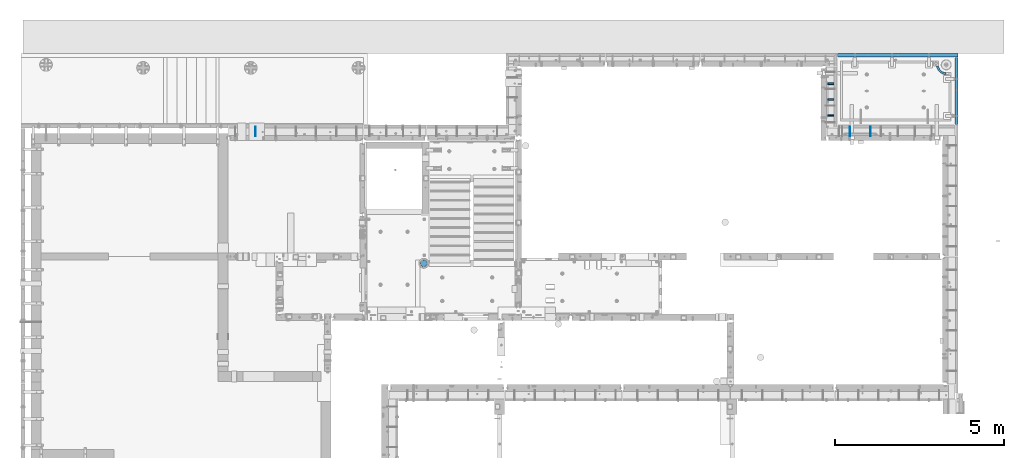
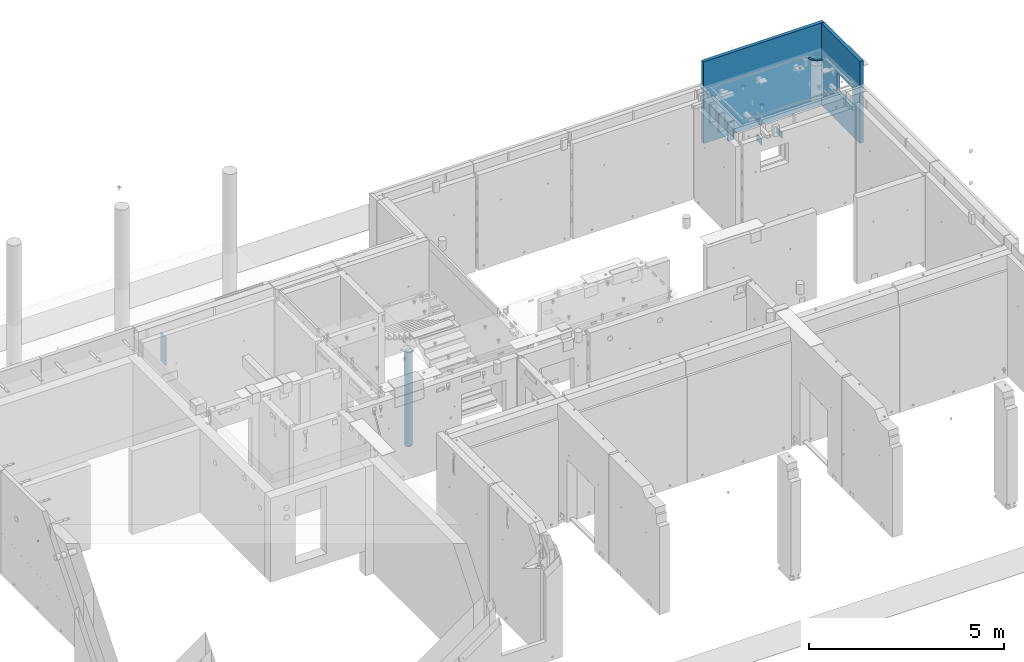
# One storey, part 179 of 264: 9 walls, 1 discrete accessory, 7 elements without a shape of their own.
"""IFC2X3 building model written with IfcOpenShell, lengths in millimetres."""

from ifc_helpers import new_model, si_unit, frame, origin_with_axes, place, context, subcontext, project, spatial, faceted_brep, material, type_object, element, aggregate, save


model = new_model("IFC2X3")

# Units and contexts
model_context = context("Model", 3, precision=1e-05, world=origin_with_axes())
body_context = subcontext(model_context, "Body", "Model", "MODEL_VIEW")
ifc_project = project(units=[si_unit("LENGTHUNIT", "METRE", prefix="MILLI"), si_unit("AREAUNIT", "SQUARE_METRE"), si_unit("VOLUMEUNIT", "CUBIC_METRE"), si_unit("MASSUNIT", "GRAM", prefix="KILO"), si_unit("TIMEUNIT", "SECOND"), si_unit("PLANEANGLEUNIT", "RADIAN"), si_unit("SOLIDANGLEUNIT", "STERADIAN"), si_unit("THERMODYNAMICTEMPERATUREUNIT", "DEGREE_CELSIUS"), si_unit("LUMINOUSINTENSITYUNIT", "LUMEN")], contexts=[model_context])

# Site, building, storey
site_placement = place(None, origin_with_axes())
site = spatial("IfcSite", under=ifc_project, at=site_placement, CompositionType="ELEMENT")
building_placement = place(site_placement, origin_with_axes())
building = spatial("IfcBuilding", under=site, at=building_placement, CompositionType="ELEMENT")
storey_placement = place(building_placement, origin_with_axes())
storey = spatial("IfcBuildingStorey", under=building, at=storey_placement, Name="K", CompositionType="ELEMENT", Elevation=0.0)

# Assembly, wall
assembly_1_placement = place(storey_placement, origin_with_axes())
assembly_1 = element("IfcElementAssembly", 1, at=assembly_1_placement, inside=storey, AssemblyPlace="NOTDEFINED", PredefinedType="REINFORCEMENT_UNIT")
ifc_material_1 = material(Name="CONCRETE/Concrete_Undefined")
wall_type_1 = type_object("IfcWallType", PredefinedType="NOTDEFINED")
wall_1_placement = place(assembly_1_placement, frame((34826.1574066181, 22853.8536757491, 81708.2082668319), z_axis=(0.00121912799960476, -0.00121916699960704, 0.999998513678269), x_axis=(0.707094358106839, -0.707117102106842, -0.00172413500026973)))
wall_1 = element("IfcWall", 2, at=wall_1_placement, type_object=wall_type_1, material=ifc_material_1, context=body_context, shape_type="Brep", body=[
    faceted_brep([(93.3118343184797, -237.308157728163, 5.0), (127.79907893135, -188.209991173673, 5.0), (124.072787641735, -185.441576728779, 4.99999999998545), (80.9180265251543, -228.100290211769, 5.00000000001455), (127.799078930633, -188.209991173673, -5.0), (93.3118343177703, -237.308157728163, -4.99999999998545), (80.9180265244431, -228.100290211762, -4.99999999998545), (124.082629280005, -185.448888485538, -4.99999999998545), (106.178139048612, -245.843349488787, -5.0), (106.178139049325, -245.843349488787, 5.00000000001455), (138.003393536512, -194.97928381541, 5.0), (138.003393535793, -194.97928381541, -5.0), (148.553521998287, -201.195886493355, -5.0), (119.480469778329, -253.681671565275, -4.99999999998545), (119.480469779044, -253.681671565268, 5.0), (148.553521999003, -201.195886493348, 5.0), (159.419558833466, -206.842177571816, 5.00000000001455), (159.419558832749, -206.842177571816, -4.99999999998545), (133.181119605213, -260.800905382079, -5.0), (133.181119605932, -260.800905382086, 5.0), (147.241252549531, -267.180870697484, 5.0), (170.57070307793, -211.902152025265, 5.00000000001455), (170.570703077217, -211.902152025265, -5.0), (147.241252548813, -267.180870697492, -5.0), (161.621013634713, -272.803482806645, -5.0), (161.621013635429, -272.803482806645, 5.00000000001455), (181.97534560251, -216.361466806389, 5.00000000001455), (181.975345601795, -216.361466806382, -5.0), (193.601158708176, -220.207481502926, -5.0), (176.279641867797, -277.652803804653, -5.0), (176.279641868512, -277.652803804653, 5.0), (193.601158708892, -220.207481502926, 5.00000000001455), (205.415187766723, -223.429294168382, 5.00000000001455), (205.415187766004, -223.429294168382, -5.0), (191.175585773741, -281.715087764271, -5.0), (191.175585774456, -281.715087764271, 5.0), (206.266621181854, -284.978819700271, 5.00000000001455), (217.383944627085, -226.017772224724, 5.0), (217.383944626366, -226.017772224717, -4.99999999998545), (206.266621181136, -284.978819700271, -5.0), (221.509970910547, -287.434748209889, -4.99999999998545), (221.509970911266, -287.434748209889, 5.0), (229.473502548291, -227.965578349642, 5.0), (229.473502547573, -227.965578349649, -4.99999999998545), (241.649592364212, -229.267191275088, -4.99999999998545), (236.862426031028, -289.075911696928, -4.99999999998545), (236.862426031745, -289.075911696928, 5.0), (241.649592364931, -229.267191275088, 5.00000000001455), (253.877699627526, -229.918921437784, 5.0), (253.87769962681, -229.918921437784, -5.0), (252.280468340545, -289.89765810519, -5.0), (252.280468341258, -289.89765810519, 5.00000000001455), (267.72039372377, -289.897658105183, 5.00000000001455), (266.123162437507, -229.918921437784, 5.00000000001455), (266.123162436788, -229.918921437777, -5.0), (267.720393723055, -289.897658105183, -5.0), (283.13843603257, -289.075911696935, -5.0), (283.138436033289, -289.075911696928, 5.00000000001455), (278.351269700101, -229.267191275088, 5.00000000001455), (278.351269699384, -229.267191275088, -5.0), (290.527359516027, -227.965578349649, -5.0), (298.490891153046, -287.434748209889, -4.99999999998545), (298.490891153766, -287.434748209889, 5.00000000001455), (290.527359516744, -227.965578349649, 5.00000000001455), (302.616917437952, -226.017772224724, 5.0), (302.61691743723, -226.017772224724, -5.0), (313.734240882461, -284.978819700271, -5.0), (313.734240883177, -284.978819700264, 5.0), (328.82527629058, -281.715087764271, 5.0), (314.585674298314, -223.429294168382, 5.00000000001455), (314.585674297596, -223.429294168389, -5.0), (328.825276289861, -281.715087764271, -4.99999999998545), (343.721220195799, -277.65280380466, -4.99999999998545), (343.721220196518, -277.652803804653, 5.0), (326.399703356141, -220.207481502934, 5.0), (326.399703355424, -220.207481502934, -5.0), (338.025516461807, -216.361466806389, -5.0), (358.379848428885, -272.803482806652, -5.0), (358.379848429604, -272.803482806652, 5.0), (338.025516462521, -216.361466806389, 5.00000000001455), (349.430158987099, -211.902152025265, 5.0), (349.430158986386, -211.902152025265, -4.99999999998545), (372.759609514787, -267.180870697484, -5.0), (372.759609515499, -267.180870697492, 5.0), (386.8197424591, -260.800905382086, 5.0), (360.581303231567, -206.842177571809, 5.00000000001455), (360.581303230854, -206.842177571809, -5.0), (386.81974245838, -260.800905382086, -4.99999999998545), (400.520392285271, -253.681671565275, -5.0), (400.520392285989, -253.681671565268, 5.0), (371.44734006603, -201.195886493355, 5.0), (371.447340065313, -201.195886493362, -5.0), (381.99746852781, -194.979283815403, -5.0), (413.82272301499, -245.84334948878, -4.99999999998545), (413.822723015703, -245.843349488794, 5.00000000001455), (381.99746852852, -194.97928381541, 5.00000000001455), (392.201783133682, -188.20999117368, 5.0), (392.20178313297, -188.209991173673, -5.0), (426.689027745833, -237.308157728163, -5.0), (426.689027746554, -237.308157728163, 5.0), (439.082835539875, -228.100290211762, 5.00000000001455), (402.031358643104, -180.907196863605, 5.00000000001455), (402.031358642391, -180.907196863598, -5.0), (439.082835539155, -228.100290211762, -5.0), (450.969014800236, -218.245847640472, -5.0), (450.96901480095, -218.245847640464, 5.0), (411.458332057049, -173.091601449101, 5.0), (411.458332056331, -173.091601449101, -5.0), (420.455981594458, -164.785359084497, -4.99999999998545), (462.313872862565, -207.772763502384, -4.99999999998545), (462.313872863273, -207.772763502391, 5.0), (420.455981595176, -164.785359084497, 5.0), (422.582513486077, -162.60144385053, 5.0), (422.591019264961, -162.592708546952, -5.0), (465.006852878565, -205.007114839013, -5.0), (464.998347099679, -205.015850142598, 5.00000000001455)], [[[0, 1, 2, 3]], [[4, 5, 6, 7]], [[1, 4, 7, 2]], [[6, 3, 2, 7]], [[5, 0, 3, 6]], [[0, 5, 8, 9]], [[1, 0, 9, 10]], [[4, 1, 10, 11]], [[5, 4, 11, 8]], [[8, 11, 12, 13]], [[9, 8, 13, 14]], [[10, 9, 14, 15]], [[11, 10, 15, 12]], [[12, 15, 16, 17]], [[13, 12, 17, 18]], [[14, 13, 18, 19]], [[15, 14, 19, 16]], [[16, 19, 20, 21]], [[17, 16, 21, 22]], [[18, 17, 22, 23]], [[19, 18, 23, 20]], [[20, 23, 24, 25]], [[21, 20, 25, 26]], [[22, 21, 26, 27]], [[23, 22, 27, 24]], [[24, 27, 28, 29]], [[25, 24, 29, 30]], [[26, 25, 30, 31]], [[27, 26, 31, 28]], [[28, 31, 32, 33]], [[29, 28, 33, 34]], [[30, 29, 34, 35]], [[31, 30, 35, 32]], [[32, 35, 36, 37]], [[33, 32, 37, 38]], [[34, 33, 38, 39]], [[35, 34, 39, 36]], [[36, 39, 40, 41]], [[37, 36, 41, 42]], [[38, 37, 42, 43]], [[39, 38, 43, 40]], [[40, 43, 44, 45]], [[41, 40, 45, 46]], [[42, 41, 46, 47]], [[43, 42, 47, 44]], [[44, 47, 48, 49]], [[45, 44, 49, 50]], [[46, 45, 50, 51]], [[47, 46, 51, 48]], [[48, 51, 52, 53]], [[49, 48, 53, 54]], [[50, 49, 54, 55]], [[51, 50, 55, 52]], [[52, 55, 56, 57]], [[53, 52, 57, 58]], [[54, 53, 58, 59]], [[55, 54, 59, 56]], [[56, 59, 60, 61]], [[57, 56, 61, 62]], [[58, 57, 62, 63]], [[59, 58, 63, 60]], [[60, 63, 64, 65]], [[61, 60, 65, 66]], [[62, 61, 66, 67]], [[63, 62, 67, 64]], [[64, 67, 68, 69]], [[65, 64, 69, 70]], [[66, 65, 70, 71]], [[67, 66, 71, 68]], [[68, 71, 72, 73]], [[69, 68, 73, 74]], [[70, 69, 74, 75]], [[71, 70, 75, 72]], [[72, 75, 76, 77]], [[73, 72, 77, 78]], [[74, 73, 78, 79]], [[75, 74, 79, 76]], [[76, 79, 80, 81]], [[77, 76, 81, 82]], [[78, 77, 82, 83]], [[79, 78, 83, 80]], [[80, 83, 84, 85]], [[81, 80, 85, 86]], [[82, 81, 86, 87]], [[83, 82, 87, 84]], [[84, 87, 88, 89]], [[85, 84, 89, 90]], [[86, 85, 90, 91]], [[87, 86, 91, 88]], [[88, 91, 92, 93]], [[89, 88, 93, 94]], [[90, 89, 94, 95]], [[91, 90, 95, 92]], [[92, 95, 96, 97]], [[93, 92, 97, 98]], [[94, 93, 98, 99]], [[95, 94, 99, 96]], [[96, 99, 100, 101]], [[97, 96, 101, 102]], [[98, 97, 102, 103]], [[99, 98, 103, 100]], [[100, 103, 104, 105]], [[101, 100, 105, 106]], [[102, 101, 106, 107]], [[103, 102, 107, 104]], [[104, 107, 108, 109]], [[105, 104, 109, 110]], [[106, 105, 110, 111]], [[107, 106, 111, 108]], [[108, 111, 112, 113]], [[109, 108, 113, 114]], [[110, 109, 114, 115]], [[111, 110, 115, 112]], [[114, 113, 112, 115]]]),
])
aggregate(assembly_1, [wall_1])

# Assembly, walls
assembly_2_placement = place(storey_placement, origin_with_axes())
assembly_2 = element("IfcElementAssembly", 3, at=assembly_2_placement, inside=storey, AssemblyPlace="NOTDEFINED", PredefinedType="REINFORCEMENT_UNIT")
ifc_material_2 = material(Name="TIMBER")
wall_type_2 = type_object("IfcWallType", PredefinedType="NOTDEFINED")
wall_2_placement = place(assembly_2_placement, frame((31499.9951872276, 21639.9997558594, 81415.0), z_axis=(0.0, 0.0, 1.0), x_axis=(1.0, 0.0, 0.0)))
wall_2 = element("IfcWall", 4, at=wall_2_placement, type_object=wall_type_2, material=ifc_material_2, context=body_context, shape_type="Brep", body=[
    faceted_brep([(0.0, 25.0, -275.0), (0.0, 25.0, 275.0), (180.0, 25.0, 275.0), (180.0, 25.0, -275.0), (0.0, -25.0, 275.0), (180.0, -25.0, 275.0), (0.0, -25.0, -275.0), (180.0, -25.0, -275.0)], [[[0, 1, 2, 3]], [[1, 4, 5, 2]], [[4, 6, 7, 5]], [[6, 0, 3, 7]], [[5, 7, 3, 2]], [[6, 4, 1, 0]]]),
])
wall_3_placement = place(assembly_2_placement, frame((31499.9951872276, 22109.9997558594, 81415.0), z_axis=(0.0, 0.0, 1.0), x_axis=(1.0, 0.0, 0.0)))
wall_3 = element("IfcWall", 5, at=wall_3_placement, type_object=wall_type_2, material=ifc_material_2, context=body_context, shape_type="Brep", body=[
    faceted_brep([(0.0, 25.0, -275.0), (0.0, 25.0, 275.0), (180.0, 25.0, 275.0), (180.0, 25.0, -275.0), (0.0, -25.0, 275.0), (180.0, -25.0, 275.0), (0.0, -25.0, -275.0), (180.0, -25.0, -275.0)], [[[0, 1, 2, 3]], [[1, 4, 5, 2]], [[4, 6, 7, 5]], [[6, 0, 3, 7]], [[5, 7, 3, 2]], [[6, 4, 1, 0]]]),
])
wall_4_placement = place(assembly_2_placement, frame((31499.9951872276, 21169.9997558594, 81415.0), z_axis=(0.0, 0.0, 1.0), x_axis=(1.0, 0.0, 0.0)))
wall_4 = element("IfcWall", 6, at=wall_4_placement, type_object=wall_type_2, material=ifc_material_2, context=body_context, shape_type="Brep", body=[
    faceted_brep([(0.0, 25.0, -275.0), (0.0, 25.0, 275.0), (180.0, 25.0, 275.0), (180.0, 25.0, -275.0), (0.0, -25.0, 275.0), (180.0, -25.0, 275.0), (0.0, -25.0, -275.0), (180.0, -25.0, -275.0)], [[[0, 1, 2, 3]], [[1, 4, 5, 2]], [[4, 6, 7, 5]], [[6, 0, 3, 7]], [[5, 7, 3, 2]], [[6, 4, 1, 0]]]),
])
aggregate(assembly_2, [wall_2, wall_3, wall_4])

assembly_3_placement = place(storey_placement, origin_with_axes())
assembly_3 = element("IfcElementAssembly", 7, at=assembly_3_placement, inside=storey, AssemblyPlace="NOTDEFINED", PredefinedType="REINFORCEMENT_UNIT")
ifc_material_3 = material(Name="Undefined")
wall_type_3 = type_object("IfcWallType", PredefinedType="NOTDEFINED")
wall_5_placement = place(assembly_3_placement, frame((32759.9902441406, 20549.9951872276, 81240.0), z_axis=(0.0, 0.0, 1.0), x_axis=(0.0, 1.0, 0.0)))
wall_5 = element("IfcWall", 8, at=wall_5_placement, type_object=wall_type_3, material=ifc_material_3, Name="(PA)", context=body_context, shape_type="Brep", body=[
    faceted_brep([(0.0, 5.0, -100.0), (0.0, 5.00000000000091, 100.0), (280.0, 5.0, 100.0), (280.0, 5.0, -100.0), (0.0, -5.0, 100.0), (280.0, -5.0, 100.0), (0.0, -5.0, -100.0), (280.0, -5.0, -100.0)], [[[0, 1, 2, 3]], [[1, 4, 5, 2]], [[4, 6, 7, 5]], [[6, 0, 3, 7]], [[5, 7, 3, 2]], [[6, 4, 1, 0]]]),
])
wall_6_placement = place(assembly_3_placement, frame((32159.9902441406, 20549.9951872276, 81240.0), z_axis=(0.0, 0.0, 1.0), x_axis=(0.0, 1.0, 0.0)))
wall_6 = element("IfcWall", 9, at=wall_6_placement, type_object=wall_type_3, material=ifc_material_3, Name="(PA)", context=body_context, shape_type="Brep", body=[
    faceted_brep([(0.0, 5.0, -100.0), (0.0, 5.00000000000091, 100.0), (280.0, 5.0, 100.0), (280.0, 5.0, -100.0), (0.0, -5.0, 100.0), (280.0, -5.0, 100.0), (0.0, -5.0, -100.0), (280.0, -5.0, -100.0)], [[[0, 1, 2, 3]], [[1, 4, 5, 2]], [[4, 6, 7, 5]], [[6, 0, 3, 7]], [[5, 7, 3, 2]], [[6, 4, 1, 0]]]),
])
aggregate(assembly_3, [wall_5, wall_6])

# Assembly, wall
assembly_4_placement = place(storey_placement, origin_with_axes())
assembly_4 = element("IfcElementAssembly", 10, at=assembly_4_placement, inside=storey, AssemblyPlace="NOTDEFINED", PredefinedType="REINFORCEMENT_UNIT")
wall_type_4 = type_object("IfcWallType", PredefinedType="NOTDEFINED")
wall_7_placement = place(assembly_4_placement, frame((14515.0002441408, 20549.9951872276, 80860.0), z_axis=(0.0, 0.0, 1.0), x_axis=(0.0, 1.0, 0.0)))
wall_7 = element("IfcWall", 11, at=wall_7_placement, type_object=wall_type_4, material=ifc_material_3, Name="(PD)", context=body_context, shape_type="Brep", body=[
    faceted_brep([(0.0, 5.0, -450.0), (0.0, 5.0, 450.0), (280.000000000055, 5.0, 450.0), (280.000000000055, 5.0, -450.0), (0.0, -5.0, 450.0), (280.000000000055, -5.0, 450.0), (0.0, -5.0, -450.0), (280.000000000055, -5.0, -450.0)], [[[0, 1, 2, 3]], [[1, 4, 5, 2]], [[4, 6, 7, 5]], [[6, 0, 3, 7]], [[5, 7, 3, 2]], [[6, 4, 1, 0]]]),
])
aggregate(assembly_4, [wall_7])

assembly_5_placement = place(storey_placement, origin_with_axes())
assembly_5 = element("IfcElementAssembly", 12, at=assembly_5_placement, inside=storey, AssemblyPlace="NOTDEFINED", PredefinedType="REINFORCEMENT_UNIT")
ifc_material_4 = material(Name="CONCRETE/C30/37")
wall_type_5 = type_object("IfcWallType", PredefinedType="NOTDEFINED")
wall_8_placement = place(assembly_5_placement, frame((35314.9964028739, 22885.007103422, 81180.0), z_axis=(0.0, 0.0, 1.0), x_axis=(0.0, -1.0, 0.0)))
wall_8 = element("IfcWall", 13, at=wall_8_placement, type_object=wall_type_5, material=ifc_material_4, context=body_context, shape_type="Brep", body=[
    faceted_brep([(790.0, 50.0, -380.0), (790.0, -50.0, -380.0), (1590.0, -50.0, -380.0), (1590.0, 50.0, -380.0), (1590.0, -50.0, 220.0), (1590.0, 50.0, 220.0), (790.0, -50.0, 220.0), (790.0, 50.0, 220.0), (1985.00366209396, 50.0, -1280.0), (0.0, 50.0, -1280.0), (0.0, 50.0, 561.000000110755), (1985.00366209396, 50.0, 561.000000110755), (0.0, -50.0, -1280.0), (1985.00366209396, -50.0, -1280.0), (0.0, 50.0, 1280.0), (0.0, -50.0, 1280.0), (1985.00366209396, -50.0, 1280.0), (1985.00366209396, 50.0, 1280.0), (1985.00366209396, 50.0, 575.000000110755), (0.0, 50.0000000000146, 575.000000110755), (0.0, 40.0000000000146, 563.000000110755), (0.0, 40.0000000000146, 573.000000110755), (1985.00366209396, 40.0000000000146, 563.000000110755), (1985.00366209396, 40.0000000000146, 573.000000110755)], [[[0, 1, 2, 3]], [[3, 2, 4, 5]], [[5, 4, 6, 7]], [[7, 6, 1, 0]], [[8, 9, 10, 11], [3, 5, 7, 0]], [[12, 9, 8, 13]], [[14, 15, 16, 17]], [[14, 17, 18, 19]], [[20, 10, 9, 12, 15, 14, 19, 21]], [[10, 20, 22, 11]], [[21, 23, 22, 20]], [[19, 18, 23, 21]], [[17, 16, 13, 8, 11, 22, 23, 18]], [[15, 12, 13, 16], [2, 1, 6, 4]]]),
])
aggregate(assembly_5, [wall_8])

assembly_6_placement = place(storey_placement, origin_with_axes())
assembly_6 = element("IfcElementAssembly", 14, at=assembly_6_placement, inside=storey, AssemblyPlace="NOTDEFINED", PredefinedType="REINFORCEMENT_UNIT")
wall_9_placement = place(assembly_6_placement, frame((31779.9964786623, 22950.0002194488, 81180.0), z_axis=(0.0, 0.0, 1.0), x_axis=(1.0, 0.0, 0.0)))
wall_9 = element("IfcWall", 15, at=wall_9_placement, type_object=wall_type_5, material=ifc_material_4, context=body_context, shape_type="Brep", body=[
    faceted_brep([(3584.99992421163, 50.0, 561.000000110755), (0.0, 50.0, 561.000000110755), (0.0, 40.0002185610028, 562.999999599575), (3584.99992421163, 40.0002185610028, 562.999999599575), (0.0, 40.0002186990023, 573.000000000786), (3584.99992421163, 40.0002186990023, 573.000000000786), (3584.99992421163, 50.0002187163445, 575.000000055239), (0.0, 50.0000000000146, 575.000000110755), (0.0, -50.0, -1280.0), (0.0, 50.0, -1280.0), (3584.99992421163, 50.0, -1280.0), (3584.99992421163, -50.0, -1280.0), (0.0, -50.0, 1280.0), (3584.99992421163, -50.0, 1280.0), (0.0, 50.0, 1280.0), (3584.99992421163, 50.0, 1280.0)], [[[0, 1, 2, 3]], [[3, 2, 4, 5]], [[6, 5, 4, 7]], [[8, 9, 10, 11]], [[12, 8, 11, 13]], [[14, 12, 13, 15]], [[14, 15, 6, 7]], [[2, 1, 9, 8, 12, 14, 7, 4]], [[10, 9, 1, 0]], [[15, 13, 11, 10, 0, 3, 5, 6]]]),
])
aggregate(assembly_6, [wall_9])

# Assembly, discrete accessory
assembly_7_placement = place(storey_placement, origin_with_axes())
assembly_7 = element("IfcElementAssembly", 16, at=assembly_7_placement, inside=storey, Name="Steel Assembly", AssemblyPlace="NOTDEFINED", PredefinedType="RIGID_FRAME")
ifc_material_5 = material()
discrete_accessory_type = type_object("IfcDiscreteAccessoryType", Name="C30/37")
discrete_accessory_placement = place(assembly_7_placement, frame((19510.0001169024, 16779.9976436332, 78490.0), z_axis=(-1.0, 3.00000001838171e-08, 0.0), x_axis=(0.0, 0.0, 1.0)))
discrete_accessory = element("IfcDiscreteAccessory", 17, at=discrete_accessory_placement, type_object=discrete_accessory_type, material=ifc_material_5, Name="C30/37", ObjectType="D209", context=body_context, shape_type="Brep", body=[
    faceted_brep([(0.0, -104.5, 0.0), (0.0, -100.939248847208, -27.0465902132128), (2970.0, -100.939248847208, -27.0465902132128), (2970.0, -104.5, 0.0), (0.0, -90.4996546954753, -52.25), (2970.0, -90.4996546954753, -52.25), (0.0, -73.8926586339949, -73.8926586339949), (2970.0, -73.8926586339949, -73.8926586339949), (0.0, -52.25, -90.4996546954753), (2970.0, -52.25, -90.4996546954753), (0.0, -27.0465902132128, -100.939248847208), (2970.0, -27.0465902132128, -100.939248847208), (0.0, 0.0, -104.5), (2970.0, 0.0, -104.5), (0.0, 27.0465902132128, -100.939248847208), (2970.0, 27.0465902132128, -100.939248847208), (0.0, 52.25, -90.4996546954753), (2970.0, 52.25, -90.4996546954753), (0.0, 73.8926586339949, -73.8926586339949), (2970.0, 73.8926586339949, -73.8926586339949), (0.0, 90.4996546954753, -52.25), (2970.0, 90.4996546954753, -52.25), (0.0, 100.939248847208, -27.0465902132128), (2970.0, 100.939248847208, -27.0465902132128), (0.0, 104.5, 0.0), (2970.0, 104.5, 0.0), (0.0, 100.939248847208, 27.0465902132128), (2970.0, 100.939248847208, 27.0465902132128), (0.0, 90.4996546954753, 52.25), (2970.0, 90.4996546954753, 52.25), (0.0, 73.8926586339949, 73.8926586339949), (2970.0, 73.8926586339949, 73.8926586339949), (0.0, 52.25, 90.4996546954753), (2970.0, 52.25, 90.4996546954753), (0.0, 27.0465902132128, 100.939248847208), (2970.0, 27.0465902132128, 100.939248847208), (0.0, 0.0, 104.5), (2970.0, 0.0, 104.5), (0.0, -27.0465902132128, 100.939248847208), (2970.0, -27.0465902132128, 100.939248847208), (0.0, -52.25, 90.4996546954753), (2970.0, -52.25, 90.4996546954753), (0.0, -73.8926586339949, 73.8926586339949), (2970.0, -73.8926586339949, 73.8926586339949), (0.0, -90.4996546954753, 52.25), (2970.0, -90.4996546954753, 52.25), (0.0, -100.939248847208, 27.0465902132128), (2970.0, -100.939248847208, 27.0465902132128)], [[[0, 1, 2, 3]], [[1, 4, 5, 2]], [[4, 6, 7, 5]], [[6, 8, 9, 7]], [[8, 10, 11, 9]], [[10, 12, 13, 11]], [[12, 14, 15, 13]], [[14, 16, 17, 15]], [[16, 18, 19, 17]], [[18, 20, 21, 19]], [[20, 22, 23, 21]], [[22, 24, 25, 23]], [[24, 26, 27, 25]], [[26, 28, 29, 27]], [[28, 30, 31, 29]], [[30, 32, 33, 31]], [[32, 34, 35, 33]], [[34, 36, 37, 35]], [[36, 38, 39, 37]], [[38, 40, 41, 39]], [[40, 42, 43, 41]], [[42, 44, 45, 43]], [[44, 46, 47, 45]], [[46, 0, 3, 47]], [[5, 7, 9, 11, 13, 15, 17, 19, 21, 23, 25, 27, 29, 31, 33, 35, 37, 39, 41, 43, 45, 47, 3, 2]], [[46, 44, 42, 40, 38, 36, 34, 32, 30, 28, 26, 24, 22, 20, 18, 16, 14, 12, 10, 8, 6, 4, 1, 0]]]),
])
aggregate(assembly_7, [discrete_accessory])

save(model, "model.ifc")
